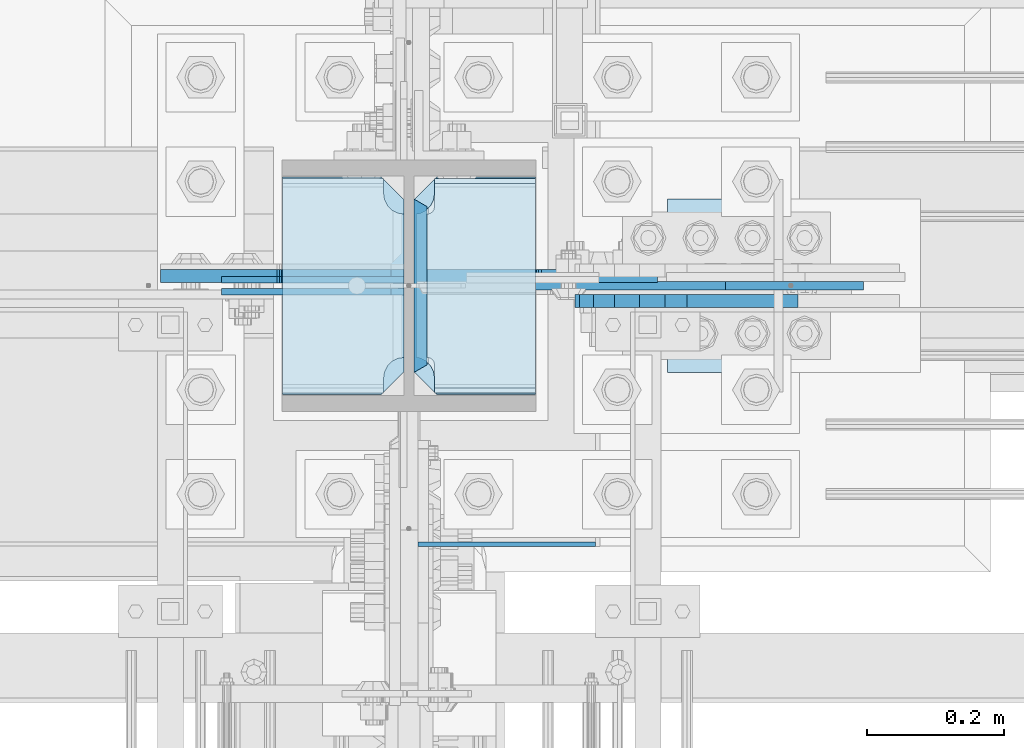
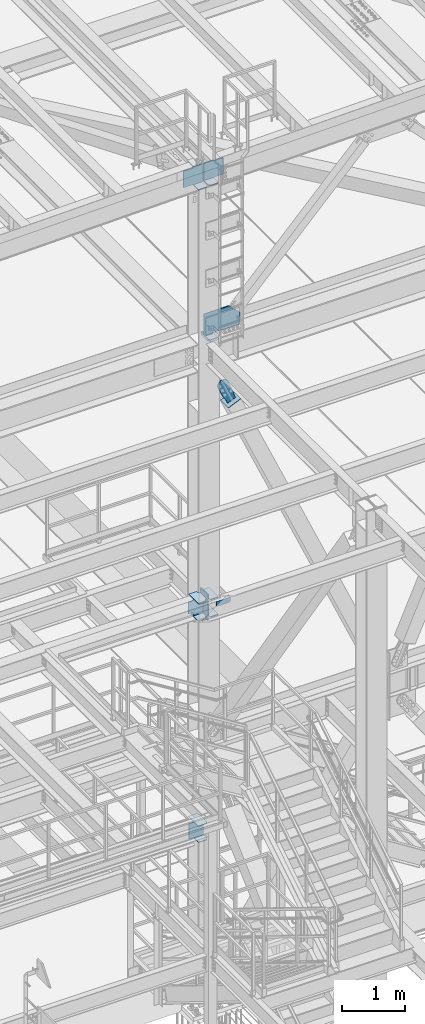
# One storey, part 3151 of 3843: 18 plates, 4 elements without a shape of their own.
"""IFC2X3 building model written with IfcOpenShell, lengths in millimetres."""

import ifcopenshell
import ifcopenshell.guid

model = None  # the IFC model being written
_history = None  # IfcOwnerHistory: only IFC2X3 demands one
_inside = {}  # id of a spatial element -> (the spatial element, [elements in it])
_under = {}  # id of a project, library or spatial element -> (it, [spatial elements below it])
_declared = {}  # id of a project -> (the project, [libraries it declares])
_typed = {}  # id of a type object -> (the type object, [elements of that type])
_made_of = {}  # id of a material, layer set ... -> (it, [elements and type objects made of it])


def new_model(schema):
    """Start an empty IFC model of exactly this schema.

    Asked for "IFC4X3", IfcOpenShell would pick the latest addendum, in which some entities
    have other attributes; the version numbers below select the first issue.
    IFC2X3 requires an IfcOwnerHistory on every rooted entity: one is made here for all.
    """
    global model, _history
    if schema == "IFC4X3":
        model = ifcopenshell.file(schema_version=(4, 3, 0, 0))
    else:
        model = ifcopenshell.file(schema=schema)
    _inside.clear()
    _under.clear()
    _declared.clear()
    _typed.clear()
    _made_of.clear()
    _history = None
    if model.schema == "IFC2X3":
        org = make("IfcOrganization", Name="unknown")
        user = make(
            "IfcPersonAndOrganization",
            ThePerson=make("IfcPerson", FamilyName="unknown"),
            TheOrganization=org,
        )
        app = make(
            "IfcApplication",
            ApplicationDeveloper=org,
            Version="unknown",
            ApplicationFullName="unknown",
            ApplicationIdentifier="unknown",
        )
        _history = make(
            "IfcOwnerHistory",
            OwningUser=user,
            OwningApplication=app,
            ChangeAction="ADDED",
            CreationDate=0,
        )
    return model


def make(cls, **values):
    """One entity of the class cls with the attributes given. An attribute that is None is left unset."""
    return model.create_entity(
        cls, **{name: value for name, value in values.items() if value is not None}
    )


def rooted(cls, **values):
    """An entity with a GlobalId (a new one), such as an element, a storey or a relation."""
    return make(cls, GlobalId=ifcopenshell.guid.new(), OwnerHistory=_history, **values)


def si_unit(unit_type, name, prefix=None):
    """IfcSIUnit, for example si_unit("LENGTHUNIT", "METRE", prefix="MILLI")."""
    return make("IfcSIUnit", UnitType=unit_type, Prefix=prefix, Name=name)


def assignment(units):
    """IfcUnitAssignment: the units of a project."""
    return None if units is None else make("IfcUnitAssignment", Units=units)


def point(xyz):
    """IfcCartesianPoint."""
    return None if xyz is None else make("IfcCartesianPoint", Coordinates=xyz)


def direction(xyz):
    """IfcDirection."""
    return None if xyz is None else make("IfcDirection", DirectionRatios=xyz)


def frame(location, z_axis=None, x_axis=None):
    """IfcAxis2Placement3D, a coordinate frame: its origin and axes. An axis left out is left unset."""
    return make(
        "IfcAxis2Placement3D",
        Location=point(location),
        Axis=direction(z_axis),
        RefDirection=direction(x_axis),
    )


def origin_with_axes():
    """The frame at (0, 0, 0) with the z axis (0, 0, 1) and the x axis (1, 0, 0) written out."""
    return frame((0.0, 0.0, 0.0), z_axis=(0.0, 0.0, 1.0), x_axis=(1.0, 0.0, 0.0))


def place(relative_to, where):
    """IfcLocalPlacement: puts the frame where relative to a parent placement (None: the world)."""
    return make(
        "IfcLocalPlacement", PlacementRelTo=relative_to, RelativePlacement=where
    )


def context(
    kind, dimensions, precision=None, world=None, true_north=None, identifier=None
):
    """IfcGeometricRepresentationContext, for example the 3D "Model" context."""
    return make(
        "IfcGeometricRepresentationContext",
        ContextIdentifier=identifier,
        ContextType=kind,
        CoordinateSpaceDimension=dimensions,
        Precision=precision,
        WorldCoordinateSystem=world,
        TrueNorth=true_north,
    )


def subcontext(parent, identifier, kind, view, scale=None):
    """IfcGeometricRepresentationSubContext, for example "Body" below "Model"."""
    return make(
        "IfcGeometricRepresentationSubContext",
        ContextIdentifier=identifier,
        ContextType=kind,
        ParentContext=parent,
        TargetScale=scale,
        TargetView=view,
    )


def project(units=None, contexts=None):
    """IfcProject with its units and contexts."""
    return rooted(
        "IfcProject",
        Name="project",
        RepresentationContexts=contexts,
        UnitsInContext=assignment(units),
    )


def spatial(cls, under=None, at=None, **own):
    """A site, building, storey or space (cls), placed at a placement, below another one or the project."""
    s = rooted(cls, ObjectPlacement=at, **own)
    if under is not None:
        _under.setdefault(under.id(), (under, []))[1].append(s)
    return s


def faces_of(points, faces, orient=None, outer=None):
    """IfcFace entities. A face is a list of loops; a loop is a list of indices into points, from 0.

    orient and outer hold one flag for each loop. By default every Orientation is true, the
    first loop of a face is its IfcFaceOuterBound and the others are IfcFaceBound.
    """
    made = []
    for i, loops in enumerate(faces):
        bounds = []
        for j, loop in enumerate(loops):
            is_outer = j == 0 if outer is None else outer[i][j]
            bounds.append(
                make(
                    "IfcFaceOuterBound" if is_outer else "IfcFaceBound",
                    Bound=make("IfcPolyLoop", Polygon=[points[k] for k in loop]),
                    Orientation=True if orient is None else orient[i][j],
                )
            )
        made.append(make("IfcFace", Bounds=bounds))
    return made


def faceted_brep(points, faces, orient=None, outer=None, voids=None):
    """IfcFacetedBrep: a solid bounded by flat faces; with voids (closed shells), ...WithVoids."""
    shared = [point(p) for p in points]
    hull = make("IfcClosedShell", CfsFaces=faces_of(shared, faces, orient, outer))
    if voids is None:
        return make("IfcFacetedBrep", Outer=hull)
    return make(
        "IfcFacetedBrepWithVoids",
        Outer=hull,
        Voids=[
            make(cls, CfsFaces=faces_of(shared, fs, o, b)) for cls, fs, o, b in voids
        ],
    )


def shape(context_of_items, identifier, shape_type, items):
    """IfcShapeRepresentation: the items that make up one representation, for example the "Body"."""
    return make(
        "IfcShapeRepresentation",
        ContextOfItems=context_of_items,
        RepresentationIdentifier=identifier,
        RepresentationType=shape_type,
        Items=items,
    )


def material(Name=None, Category=None):
    """IfcMaterial."""
    return make("IfcMaterial", Name=Name, Category=Category)


def made_of(thing, what):
    """Note that an element or type object is made of a material, layer set ...; save() writes the relation."""
    if what is not None:
        _made_of.setdefault(what.id(), (what, []))[1].append(thing)
    return thing


def type_object(cls, material=None, **own):
    """A type object (cls), such as IfcWallType, which elements share."""
    return made_of(rooted(cls, **own), material)


def element(
    cls,
    number,
    at=None,
    inside=None,
    cuts=None,
    type_object=None,
    material=None,
    context=None,
    identifier="Body",
    shape_type=None,
    held_by="IfcProductDefinitionShape",
    body=None,
    shapes=None,
    **own,
):
    """One element of the class cls, such as IfcWall. Its Tag is "e" and its number.

    at: its placement. inside: the storey or other place that contains it. cuts: it is an
    opening in that element (IfcRelVoidsElement). A single representation is given by context,
    identifier, shape_type and body (its items); several are given by shapes. held_by: the class
    of the entity that holds the representations. save() writes the other relations.
    """
    e = rooted(cls, Tag="e%d" % number, ObjectPlacement=at, **own)
    if body is not None:
        shapes = [shape(context, identifier, shape_type, body)]
    if shapes is not None:
        e.Representation = make(held_by, Representations=shapes)
    if inside is not None:
        _inside.setdefault(inside.id(), (inside, []))[1].append(e)
    if cuts is not None:
        rooted(
            "IfcRelVoidsElement", RelatingBuildingElement=cuts, RelatedOpeningElement=e
        )
    if type_object is not None:
        _typed.setdefault(type_object.id(), (type_object, []))[1].append(e)
    return made_of(e, material)


def aggregate(whole, parts):
    """IfcRelAggregates: a whole, such as a stair, and the parts it consists of."""
    return rooted("IfcRelAggregates", RelatingObject=whole, RelatedObjects=parts)


def save(model, path):
    """Write the relations noted so far, then the file.

    IfcRelAggregates (storeys below a building ...), IfcRelContainedInSpatialStructure (elements
    in a storey), IfcRelDefinesByType, IfcRelAssociatesMaterial and IfcRelDeclares: one each for
    every whole, place, type object, material and project.
    """
    for whole, parts in _under.values():
        aggregate(whole, parts)
    for where, things in _inside.values():
        rooted(
            "IfcRelContainedInSpatialStructure",
            RelatedElements=things,
            RelatingStructure=where,
        )
    for kind, things in _typed.values():
        rooted("IfcRelDefinesByType", RelatedObjects=things, RelatingType=kind)
    for what, things in _made_of.values():
        rooted("IfcRelAssociatesMaterial", RelatedObjects=things, RelatingMaterial=what)
    for by, libraries in _declared.values():
        rooted("IfcRelDeclares", RelatingContext=by, RelatedDefinitions=libraries)
    model.write(path)


model = new_model("IFC2X3")

# Units and contexts
model_context = context("Model", 3, precision=1e-05, world=origin_with_axes())
body_context = subcontext(model_context, "Body", "Model", "MODEL_VIEW")
ifc_project = project(units=[si_unit("LENGTHUNIT", "METRE", prefix="MILLI"), si_unit("AREAUNIT", "SQUARE_METRE"), si_unit("VOLUMEUNIT", "CUBIC_METRE"), si_unit("MASSUNIT", "GRAM", prefix="KILO"), si_unit("TIMEUNIT", "SECOND"), si_unit("PLANEANGLEUNIT", "RADIAN"), si_unit("SOLIDANGLEUNIT", "STERADIAN"), si_unit("THERMODYNAMICTEMPERATUREUNIT", "DEGREE_CELSIUS"), si_unit("LUMINOUSINTENSITYUNIT", "LUMEN")], contexts=[model_context])

# Site, building, storey
site_placement = place(None, origin_with_axes())
site = spatial("IfcSite", under=ifc_project, at=site_placement, CompositionType="ELEMENT")
building_placement = place(site_placement, origin_with_axes())
building = spatial("IfcBuilding", under=site, at=building_placement, Name="Undefined", CompositionType="ELEMENT")
storey_placement = place(building_placement, origin_with_axes())
storey = spatial("IfcBuildingStorey", under=building, at=storey_placement, Name="Undefined", CompositionType="ELEMENT", Elevation=0.0)

# Assembly, plates
assembly_1_placement = place(storey_placement, origin_with_axes())
assembly_1 = element("IfcElementAssembly", 1, at=assembly_1_placement, inside=storey, Name="COLUMN", AssemblyPlace="NOTDEFINED", PredefinedType="RIGID_FRAME")
ifc_material_1 = material(Name="STEEL/A572-50")
plate_type_1 = type_object("IfcPlateType", PredefinedType="NOTDEFINED")
plate_1_placement = place(assembly_1_placement, frame((55745.85625, 25776.2375, 37122.1), z_axis=(0.0, -1.0, 0.0), x_axis=(1.0, 0.0, 0.0)))
plate_1 = element("IfcPlate", 2, at=plate_1_placement, type_object=plate_type_1, material=ifc_material_1, Name="PLATE", context=body_context, shape_type="Brep", body=[
    faceted_brep([(147.637499618526, 6.34999999999854, 10.5078482601057), (147.637499618526, -6.34999999999854, 3.17549995151785), (0.0, -6.34999999999854, 3.17549995151785), (0.0, 6.34999999999854, 10.5078482601057), (0.0, 6.34999999999854, 310.168151738297), (0.0, -6.34999999999854, 317.500500046885), (147.637499618526, -6.34999999999854, 317.500500046885), (147.637499618526, 6.34999999999854, 310.168151738297), (147.637499618526, -6.34999999999854, 295.275000381469), (147.637499618526, 6.34999999999854, 295.275000381469), (149.113757464445, -6.34999999999854, 285.954275170756), (149.113757464445, 6.34999999999854, 285.954275170756), (153.398024598544, -6.34999999999854, 277.545927484975), (153.398024598544, 6.34999999999854, 277.545927484975), (160.070927103501, -6.34999999999854, 270.873024980021), (160.070927103501, 6.34999999999854, 270.873024980021), (168.479274789279, -6.34999999999854, 266.588757845919), (168.479274789279, 6.34999999999854, 266.588757845919), (177.799999999996, -6.34999999999854, 265.112499999999), (177.799999999996, 6.34999999999854, 265.112499999999), (177.799999999996, -6.34999999999854, 55.5625), (177.799999999996, 6.34999999999854, 55.5625), (168.479274789279, -6.34999999999854, 54.0862421540805), (168.479274789279, 6.34999999999854, 54.0862421540805), (160.070927103501, -6.34999999999854, 49.8019750199819), (160.070927103501, 6.34999999999854, 49.8019750199819), (153.398024598544, -6.34999999999854, 43.1290725150247), (153.398024598544, 6.34999999999854, 43.1290725150247), (149.113757464445, -6.34999999999854, 34.720724829247), (149.113757464445, 6.34999999999854, 34.720724829247), (147.637499618526, -6.34999999999854, 25.3999996185303), (147.637499618526, 6.34999999999854, 25.3999996185303)], [[[0, 1, 2, 3]], [[4, 5, 6, 7]], [[3, 2, 5, 4]], [[8, 9, 7, 6]], [[8, 10, 11, 9]], [[10, 12, 13, 11]], [[12, 14, 15, 13]], [[14, 16, 17, 15]], [[16, 18, 19, 17]], [[18, 20, 21, 19]], [[20, 22, 23, 21]], [[22, 24, 25, 23]], [[24, 26, 27, 25]], [[26, 28, 29, 27]], [[28, 30, 31, 29]], [[31, 30, 1, 0]], [[4, 7, 9, 11, 13, 15, 17, 19, 21, 23, 25, 27, 29, 31, 0, 3]], [[1, 30, 28, 26, 24, 22, 20, 18, 16, 14, 12, 10, 8, 6, 5, 2]]]),
])
plate_2_placement = place(assembly_1_placement, frame((55745.85625, 25776.2375, 37458.65), z_axis=(0.0, -1.0, 0.0), x_axis=(1.0, 0.0, 0.0)))
plate_2 = element("IfcPlate", 3, at=plate_2_placement, type_object=plate_type_1, material=ifc_material_1, Name="PLATE", context=body_context, shape_type="Brep", body=[
    faceted_brep([(147.637499618526, 6.34999999999854, 10.5078482601057), (147.637499618526, -6.34999999999854, 3.17549995151785), (0.0, -6.34999999999854, 3.17549995151785), (0.0, 6.34999999999854, 10.5078482601057), (0.0, 6.34999999999854, 310.168151738297), (0.0, -6.34999999999854, 317.500500046885), (147.637499618526, -6.34999999999854, 317.500500046885), (147.637499618526, 6.34999999999854, 310.168151738297), (147.637499618526, -6.34999999999854, 295.275000381469), (147.637499618526, 6.34999999999854, 295.275000381469), (149.113757464445, -6.34999999999854, 285.954275170756), (149.113757464445, 6.34999999999854, 285.954275170756), (153.398024598544, -6.34999999999854, 277.545927484975), (153.398024598544, 6.34999999999854, 277.545927484975), (160.070927103501, -6.34999999999854, 270.873024980021), (160.070927103501, 6.34999999999854, 270.873024980021), (168.479274789279, -6.34999999999854, 266.588757845919), (168.479274789279, 6.34999999999854, 266.588757845919), (177.799999999996, -6.34999999999854, 265.112499999999), (177.799999999996, 6.34999999999854, 265.112499999999), (177.799999999996, -6.34999999999854, 55.5625), (177.799999999996, 6.34999999999854, 55.5625), (168.479274789279, -6.34999999999854, 54.0862421540805), (168.479274789279, 6.34999999999854, 54.0862421540805), (160.070927103501, -6.34999999999854, 49.8019750199819), (160.070927103501, 6.34999999999854, 49.8019750199819), (153.398024598544, -6.34999999999854, 43.1290725150247), (153.398024598544, 6.34999999999854, 43.1290725150247), (149.113757464445, -6.34999999999854, 34.720724829247), (149.113757464445, 6.34999999999854, 34.720724829247), (147.637499618526, -6.34999999999854, 25.3999996185303), (147.637499618526, 6.34999999999854, 25.3999996185303)], [[[0, 1, 2, 3]], [[4, 5, 6, 7]], [[3, 2, 5, 4]], [[8, 9, 7, 6]], [[8, 10, 11, 9]], [[10, 12, 13, 11]], [[12, 14, 15, 13]], [[14, 16, 17, 15]], [[16, 18, 19, 17]], [[18, 20, 21, 19]], [[20, 22, 23, 21]], [[22, 24, 25, 23]], [[24, 26, 27, 25]], [[26, 28, 29, 27]], [[28, 30, 31, 29]], [[31, 30, 1, 0]], [[4, 7, 9, 11, 13, 15, 17, 19, 21, 23, 25, 27, 29, 31, 0, 3]], [[1, 30, 28, 26, 24, 22, 20, 18, 16, 14, 12, 10, 8, 6, 5, 2]]]),
])

# Assembly, plate
assembly_2_placement = place(storey_placement, origin_with_axes())
assembly_2 = element("IfcElementAssembly", 4, at=assembly_2_placement, inside=storey, Name="BEAM", AssemblyPlace="NOTDEFINED", PredefinedType="RIGID_FRAME")
plate_type_2 = type_object("IfcPlateType", PredefinedType="NOTDEFINED")
plate_3_placement = place(assembly_2_placement, frame((55943.5, 25237.8457862042, 37471.35), z_axis=(0.0, 0.0, 1.0), x_axis=(1.0, 0.0, 0.0)))
plate_3 = element("IfcPlate", 5, at=plate_3_placement, type_object=plate_type_2, material=ifc_material_1, Name="PLATE", context=body_context, shape_type="Brep", body=[
    faceted_brep([(0.0, -3.17499999999927, 0.0), (0.0, -3.17499999999927, 95.25), (-2.44140610448085e-05, 3.17500000000291, 95.2499999999927), (0.0, 3.17499999999927, 0.0), (260.350006103516, -3.17499999999927, 95.25), (260.350006103516, 3.17499999999927, 95.25), (260.350006103516, -3.17499999999927, 19.0499992370605), (260.350006103516, 3.17499999999927, 19.0499992370605), (241.300006866455, -3.17499999999927, 0.0), (241.300006866455, 3.17499999999927, 0.0)], [[[0, 1, 2, 3]], [[1, 4, 5, 2]], [[4, 6, 7, 5]], [[6, 8, 9, 7]], [[8, 0, 3, 9]], [[5, 7, 9, 3, 2]], [[8, 6, 4, 1, 0]]]),
])
aggregate(assembly_2, [plate_3])

# Plate
plate_type_3 = type_object("IfcPlateType", PredefinedType="NOTDEFINED")
plate_4_placement = place(assembly_1_placement, frame((55745.85625, 25774.65, 32850.1375), z_axis=(0.0, -1.0, 0.0), x_axis=(1.0, 0.0, 0.0)))
plate_4 = element("IfcPlate", 6, at=plate_4_placement, type_object=plate_type_3, material=ifc_material_1, Name="PLATE", context=body_context, shape_type="Brep", body=[
    faceted_brep([(0.0, -4.76249999999709, 0.0), (0.0, -4.76249999785796, 317.500000005042), (0.0, 4.76250000210712, 317.50000000505), (0.0, 4.76249999999709, 0.0), (144.462501525879, -4.76249999999709, 317.5), (144.462501525879, 4.76249999999709, 317.5), (177.800003051758, -4.76249999999709, 284.162498474121), (177.800003051758, 4.76249999999709, 284.162498474121), (177.800003051758, -4.76249999999709, 33.3375015258789), (177.800003051758, 4.76249999999709, 33.3375015258789), (144.462501525879, -4.76249999999709, 0.0), (144.462501525879, 4.76249999999709, 0.0)], [[[0, 1, 2, 3]], [[1, 4, 5, 2]], [[4, 6, 7, 5]], [[6, 8, 9, 7]], [[8, 10, 11, 9]], [[10, 0, 3, 11]], [[5, 7, 9, 11, 3, 2]], [[10, 8, 6, 4, 1, 0]]]),
])

plate_5_placement = place(assembly_1_placement, frame((55745.85625, 25774.65, 33164.4625), z_axis=(0.0, -1.0, 0.0), x_axis=(1.0, 0.0, 0.0)))
plate_5 = element("IfcPlate", 7, at=plate_5_placement, type_object=plate_type_3, material=ifc_material_1, Name="PLATE", context=body_context, shape_type="Brep", body=[
    faceted_brep([(0.0, -4.76249999999709, 0.0), (0.0, -4.76249999785796, 317.500000005042), (0.0, 4.76250000210712, 317.50000000505), (0.0, 4.76249999999709, 0.0), (144.462501525879, -4.76249999999709, 317.5), (144.462501525879, 4.76249999999709, 317.5), (177.800003051758, -4.76249999999709, 284.162498474121), (177.800003051758, 4.76249999999709, 284.162498474121), (177.800003051758, -4.76249999999709, 33.3375015258789), (177.800003051758, 4.76249999999709, 33.3375015258789), (144.462501525879, -4.76249999999709, 0.0), (144.462501525879, 4.76249999999709, 0.0)], [[[0, 1, 2, 3]], [[1, 4, 5, 2]], [[4, 6, 7, 5]], [[6, 8, 9, 7]], [[8, 10, 11, 9]], [[10, 0, 3, 11]], [[5, 7, 9, 11, 3, 2]], [[10, 8, 6, 4, 1, 0]]]),
])

plate_type_4 = type_object("IfcPlateType", PredefinedType="NOTDEFINED")
plate_6_placement = place(assembly_1_placement, frame((56115.74375, 25455.5625, 42452.925), z_axis=(0.0, 1.0, 0.0), x_axis=(-1.0, 0.0, 0.0)))
plate_6 = element("IfcPlate", 8, at=plate_6_placement, type_object=plate_type_4, material=ifc_material_1, Name="PLATE", context=body_context, shape_type="Brep", body=[
    faceted_brep([(160.070927103507, 9.33349681380059, 49.8019750199746), (156.294129000915, 15.875, 46.0251769173919), (156.294129000915, 15.875, 274.649823082611), (160.070927103507, 9.33349681380059, 270.873024980028), (168.479274789286, -5.22995923629787, 266.588757845922), (174.625000047685, -15.875, 265.615370590487), (174.625000047685, -15.875, 55.0596294095158), (168.479274789286, -5.22995923629787, 54.0862421540805), (147.637499618526, 15.875, 21.5063709990791), (147.637499618526, -15.875, 3.17549995230729), (0.0, -15.875, 3.17549995230729), (0.0, 15.875, 21.5063709990791), (0.0, 15.875, 299.169629000906), (0.0, -15.875, 317.500500047678), (147.637499618526, -15.875, 317.500500047678), (147.637499618526, 15.875, 299.169629000906), (147.637499618531, -15.875, 295.275000381473), (147.637499618531, 15.875, 295.275000381473), (149.113757464449, -15.875, 285.954275170763), (149.113757464449, 15.875, 285.954275170763), (153.398024598551, -15.875, 277.545927484985), (153.398024598551, 15.875, 277.545927484985), (160.070927103507, -15.875, 270.873024980028), (168.479274789286, -15.875, 266.588757845922), (168.479274789286, -15.875, 54.0862421540805), (160.070927103507, -15.875, 49.8019750199746), (153.398024598551, -15.875, 43.1290725150175), (153.398024598551, 15.875, 43.1290725150175), (149.113757464449, -15.875, 34.7207248292398), (149.113757464449, 15.875, 34.7207248292398), (147.637499618531, -15.875, 25.3999996185303), (147.637499618531, 15.875, 25.3999996185303)], [[[0, 1, 2, 3, 4, 5, 6, 7]], [[8, 9, 10, 11]], [[12, 13, 14, 15]], [[13, 12, 11, 10]], [[16, 17, 15, 14]], [[16, 18, 19, 17]], [[18, 20, 21, 19]], [[21, 20, 22, 3, 2]], [[22, 23, 4, 3]], [[23, 5, 4]], [[24, 7, 6]], [[24, 25, 0, 7]], [[25, 26, 27, 1, 0]], [[26, 28, 29, 27]], [[28, 30, 31, 29]], [[31, 30, 9, 8]], [[27, 29, 31, 8, 11, 12, 15, 17, 19, 21, 2, 1]], [[9, 30, 28, 26, 25, 24, 6, 5, 23, 22, 20, 18, 16, 14, 13, 10]]]),
])

plate_type_5 = type_object("IfcPlateType", PredefinedType="NOTDEFINED")
plate_7_placement = place(assembly_1_placement, frame((56115.74375, 25457.15, 45462.0789825252), z_axis=(0.0, 1.0, 0.0), x_axis=(-1.0, 0.0, 0.0)))
plate_7 = element("IfcPlate", 9, at=plate_7_placement, type_object=plate_type_5, material=ifc_material_1, Name="PLATE", context=body_context, shape_type="Brep", body=[
    faceted_brep([(0.0, -9.52500000000146, 0.0), (0.0, -9.52500000000146, 317.5), (0.0, 9.52500000000146, 317.5), (0.0, 9.52500000000146, 0.0), (144.462501525879, -9.52500000000146, 317.5), (144.462501525879, 9.52500000000146, 317.5), (177.800003051758, -9.52500000000146, 284.162498474121), (177.800003051758, 9.52500000000146, 284.162498474121), (177.800003051758, -9.52500000000146, 33.3375015258789), (177.800003051758, 9.52500000000146, 33.3375015258789), (144.462501525879, -9.52500000000146, 0.0), (144.462501525879, 9.52500000000146, 0.0)], [[[0, 1, 2, 3]], [[1, 4, 5, 2]], [[4, 6, 7, 5]], [[6, 8, 9, 7]], [[8, 10, 11, 9]], [[10, 0, 3, 11]], [[5, 7, 9, 11, 3, 2]], [[10, 8, 6, 4, 1, 0]]]),
])

plate_8_placement = place(assembly_1_placement, frame((55745.8562499977, 25774.6499999999, 45450.5073620301), z_axis=(0.0, -1.0, 0.0), x_axis=(1.0, 0.0, 0.0)))
plate_8 = element("IfcPlate", 10, at=plate_8_placement, type_object=plate_type_5, material=ifc_material_1, Name="PLATE", context=body_context, shape_type="Brep", body=[
    faceted_brep([(0.0, -9.52500000000146, 0.0), (0.0, -9.52500000000146, 317.5), (0.0, 9.52500000000146, 317.5), (0.0, 9.52500000000146, 0.0), (144.462501525879, -9.52500000000146, 317.5), (144.462501525879, 9.52500000000146, 317.5), (177.800003051758, -9.52500000000146, 284.162498474121), (177.800003051758, 9.52500000000146, 284.162498474121), (177.800003051758, -9.52500000000146, 33.3375015258789), (177.800003051758, 9.52500000000146, 33.3375015258789), (144.462501525879, -9.52500000000146, 0.0), (144.462501525879, 9.52500000000146, 0.0)], [[[0, 1, 2, 3]], [[1, 4, 5, 2]], [[4, 6, 7, 5]], [[6, 8, 9, 7]], [[8, 10, 11, 9]], [[10, 0, 3, 11]], [[5, 7, 9, 11, 3, 2]], [[10, 8, 6, 4, 1, 0]]]),
])

plate_type_6 = type_object("IfcPlateType", PredefinedType="NOTDEFINED")
plate_9_placement = place(assembly_1_placement, frame((55947.46875, 25489.0875, 37541.2), z_axis=(0.0, 1.0, 0.0), x_axis=(0.0, 0.0, -1.0)))
plate_9 = element("IfcPlate", 11, at=plate_9_placement, type_object=plate_type_6, material=ifc_material_1, Name="PLATE", context=body_context, shape_type="Brep", body=[
    faceted_brep([(0.0, -9.52500000000146, 242.626477373742), (501.650000000001, -9.52500000000146, 242.626477373742), (501.650000000001, 9.52500000000146, 253.625), (0.0, 9.52500000000146, 253.625), (501.650000000001, -9.52500000000146, 10.9985226253266), (501.650000000001, 9.52500000000146, 0.0), (0.0, 9.52500000000146, 0.0), (0.0, -9.52500000000146, 10.9985226253266)], [[[0, 1, 2, 3]], [[2, 1, 4, 5]], [[3, 2, 5, 6]], [[0, 3, 6, 7]], [[1, 0, 7, 4]], [[6, 5, 4, 7]]]),
])

# Assembly, plate
assembly_3_placement = place(storey_placement, origin_with_axes())
assembly_3 = element("IfcElementAssembly", 12, at=assembly_3_placement, inside=storey, AssemblyPlace="NOTDEFINED", PredefinedType="RIGID_FRAME")
ifc_material_2 = material(Name="STEEL/A36")
plate_type_7 = type_object("IfcPlateType", PredefinedType="NOTDEFINED")
plate_10_placement = place(assembly_3_placement, frame((56471.840024458, 25593.675, 41169.8056493382), z_axis=(-0.915217968956094, 0.0, -0.402959140980674), x_axis=(0.402959140980677, 0.0, -0.915217968956092)))
plate_10 = element("IfcPlate", 13, at=plate_10_placement, type_object=plate_type_7, material=ifc_material_2, context=body_context, shape_type="Brep", body=[
    faceted_brep([(0.0, -9.52500000000146, 0.0), (-101.599999999169, -9.52499999999418, -17.6403935107228), (-101.599999999169, 9.52499999999418, -17.6403935107228), (0.0, 9.52500000000146, 0.0), (-320.279297659972, -9.52499999999418, -17.640393512258), (-320.279297659972, 9.52499999999418, -17.640393512258), (-357.3374051259, -9.52499999999418, -10.2690776257878), (-357.3374051259, 9.52499999999418, -10.2690776257878), (-388.753751662653, -9.52499999999418, 10.7226540115298), (-388.753751662653, 9.52499999999418, 10.7226540115298), (-409.745483299826, -9.52499999999418, 42.1390005483918), (-409.745483299826, 9.52499999999418, 42.1390005483918), (-417.116799186137, -9.52499999999418, 79.1971049608474), (-417.116799186137, 9.52499999999418, 79.1971049608474), (-409.745483299252, -9.52499999999418, 116.255212426157), (-409.745483299252, 9.52499999999418, 116.255212426157), (-388.75375166202, -9.52499999999418, 147.671558962465), (-388.75375166202, 9.52499999999418, 147.671558962465), (-357.33740512564, -9.52499999999418, 168.663290599579), (-357.33740512564, 9.52499999999418, 168.663290599579), (-320.279299186061, -9.52499999999418, 176.034606486319), (-320.279299186061, 9.52499999999418, 176.034606486319), (-101.599999997048, -9.52499999999418, 176.034606487883), (-101.599999997048, 9.52499999999418, 176.034606487883), (1.71894498635083e-09, -9.52499999999418, 158.39421297863), (1.71894498635083e-09, 9.52499999999418, 158.39421297863), (69.8500000010408, -9.52499999999418, 158.394212979103), (69.8500000010408, 9.52499999999418, 158.394212979103), (69.8499999979995, -9.52499999999418, -4.00177668780088e-10), (69.8499999979995, 9.52499999999418, -4.00177668780088e-10)], [[[0, 1, 2, 3]], [[1, 4, 5, 2]], [[4, 6, 7, 5]], [[6, 8, 9, 7]], [[8, 10, 11, 9]], [[10, 12, 13, 11]], [[12, 14, 15, 13]], [[14, 16, 17, 15]], [[16, 18, 19, 17]], [[18, 20, 21, 19]], [[20, 22, 23, 21]], [[22, 24, 25, 23]], [[24, 26, 27, 25]], [[26, 28, 29, 27]], [[28, 0, 3, 29]], [[5, 7, 9, 11, 13, 15, 17, 19, 21, 23, 25, 27, 29, 3, 2]], [[28, 26, 24, 22, 20, 18, 16, 14, 12, 10, 8, 6, 4, 1, 0]]]),
])
aggregate(assembly_3, [plate_10])

assembly_4_placement = place(storey_placement, origin_with_axes())
assembly_4 = element("IfcElementAssembly", 14, at=assembly_4_placement, inside=storey, Name="Plate", AssemblyPlace="NOTDEFINED", PredefinedType="RIGID_FRAME")
plate_type_8 = type_object("IfcPlateType", PredefinedType="NOTDEFINED")
plate_11_placement = place(assembly_4_placement, frame((56309.9920282698, 25742.9, 41025.6944824161), z_axis=(0.9152179689561, 0.0, 0.402959140980659), x_axis=(0.0, -1.0, 0.0)))
plate_11 = element("IfcPlate", 15, at=plate_11_placement, type_object=plate_type_8, material=ifc_material_2, Name="Plate", context=body_context, shape_type="Brep", body=[
    faceted_brep([(0.0, -3.17499999999927, 0.0), (0.0, -3.17499999965185, 254.000000005151), (0.0, 3.17500000035216, 254.000000005166), (0.0, 3.17499999999927, 0.0), (254.0, -3.17499999965185, 254.000000005151), (254.0, 3.17500000035216, 254.000000005166), (254.0, -3.17500000000291, 0.0), (254.0, 3.17499999999927, 1.45519152283669e-11)], [[[0, 1, 2, 3]], [[1, 4, 5, 2]], [[4, 6, 7, 5]], [[6, 0, 3, 7]], [[5, 7, 3, 2]], [[6, 4, 1, 0]]]),
])
aggregate(assembly_4, [plate_11])

# Plate
plate_type_9 = type_object("IfcPlateType", PredefinedType="NOTDEFINED")
plate_12_placement = place(assembly_1_placement, frame((55937.9437500005, 25615.8999998765, 42468.7999999995), z_axis=(1.0, 0.0, 0.0), x_axis=(0.0, 0.0, 1.0)))
plate_12 = element("IfcPlate", 16, at=plate_12_placement, type_object=plate_type_9, material=ifc_material_1, Name="PLATE", context=body_context, shape_type="Brep", body=[
    faceted_brep([(19.0499992370605, -6.34999999999854, 0.0), (0.0, -6.34999999999854, 19.0499992370605), (0.0, 6.34999999999854, 19.0499992370605), (19.0499992370605, 6.34999999999854, 0.0), (25.4000002011162, -6.35000000000582, 153.193750006707), (25.4000002011162, 6.35000000000582, 153.193750006707), (0.0, 6.35000000000582, 153.193750006707), (0.0, -6.35000000000582, 153.193750006707), (30.2600797191626, -6.35000000000582, 154.160479929295), (30.2600797191626, 6.35000000000582, 154.160479929295), (34.3802561873163, -6.35000000000582, 156.913493829772), (34.3802561873163, 6.35000000000582, 156.913493829772), (37.1332700877902, -6.35000000000582, 161.033670297926), (37.1332700877902, 6.35000000000582, 161.033670297926), (38.1000000103813, -6.35000000000582, 165.893749815972), (38.1000000103813, 6.35000000000582, 165.893749815972), (38.1000000103813, -6.35000000000582, 191.293750197441), (38.1000000103813, 6.35000000000582, 191.293750197441), (37.1332700877902, -6.35000000000582, 196.153829715488), (37.1332700877902, 6.35000000000582, 196.153829715488), (34.3802561873163, -6.35000000000582, 200.274006183641), (34.3802561873163, 6.35000000000582, 200.274006183641), (30.2600797191626, -6.35000000000582, 203.027020084119), (30.2600797191626, 6.35000000000582, 203.027020084119), (25.4000002011162, -6.35000000000582, 203.993750006706), (25.4000002011162, 6.35000000000582, 203.993750006706), (12.6999999999971, -6.35000000000582, 203.993750006706), (12.6999999999971, 6.35000000000582, 203.993750006706), (12.7000000005137, -6.34999999999854, 657.538050779636), (12.7000000005137, 6.34999999999854, 657.538050779636), (237.691562785571, -6.34999999999854, 657.538050779636), (237.691562785571, 6.34999999999854, 657.538050779636), (431.157586934583, -6.34999999999854, 455.956162952447), (431.157586934583, 6.34999999999854, 455.956162952447), (431.157586934591, -6.35000000000582, 0.0), (431.157586934591, 6.35000000000582, 0.0)], [[[0, 1, 2, 3]], [[4, 5, 6, 7]], [[8, 9, 5, 4]], [[10, 11, 9, 8]], [[12, 13, 11, 10]], [[14, 15, 13, 12]], [[16, 17, 15, 14]], [[18, 19, 17, 16]], [[20, 21, 19, 18]], [[22, 23, 21, 20]], [[24, 25, 23, 22]], [[26, 27, 25, 24]], [[28, 29, 27, 26]], [[30, 31, 29, 28]], [[30, 32, 33, 31]], [[32, 34, 35, 33]], [[35, 34, 0, 3]], [[6, 5, 9, 11, 13, 15, 17, 19, 21, 23, 25, 27, 29, 31, 33, 35, 3, 2]], [[2, 1, 7, 6]], [[34, 32, 30, 28, 26, 24, 22, 20, 18, 16, 14, 12, 10, 8, 4, 7, 1, 0]]]),
])

plate_type_10 = type_object("IfcPlateType", PredefinedType="NOTDEFINED")
plate_13_placement = place(assembly_1_placement, frame((56115.74375, 25455.5625, 37122.1), z_axis=(0.0, 1.0, 0.0), x_axis=(-1.0, 0.0, 0.0)))
plate_13 = element("IfcPlate", 17, at=plate_13_placement, type_object=plate_type_10, material=ifc_material_1, Name="PLATE", context=body_context, shape_type="Brep", body=[
    faceted_brep([(147.637499809265, 6.34999999999854, 10.5068482617207), (147.637499809265, -6.34999999999854, 3.17449995313291), (0.0, -6.34999999999854, 3.17449995313291), (0.0, 6.34999999999854, 10.5068482617207), (0.0, 6.34999999999854, 310.167151739912), (0.0, -6.34999999999854, 317.4995000485), (147.637499809265, -6.34999999999854, 317.4995000485), (147.637499809265, 6.34999999999854, 310.167151739912), (147.637499809265, -6.34999999999854, 276.225000190734), (147.637499809265, 6.34999999999854, 276.225000190734), (148.483388518755, -6.34999999999854, 271.972430475587), (148.483388518755, 6.34999999999854, 271.972430475587), (150.892275759194, -6.34999999999854, 268.367275949928), (150.892275759194, 6.34999999999854, 268.367275949928), (154.49743028485, -6.34999999999854, 265.958388709485), (154.49743028485, 6.34999999999854, 265.958388709485), (158.75, -6.34999999999854, 265.112499999999), (158.75, 6.34999999999854, 265.112499999999), (158.75, -6.34999999999854, 55.5625), (158.75, 6.34999999999854, 55.5625), (154.49743028485, -6.34999999999854, 54.7166112905143), (154.49743028485, 6.34999999999854, 54.7166112905143), (150.892275759194, -6.34999999999854, 52.3077240500716), (150.892275759194, 6.34999999999854, 52.3077240500716), (148.483388518755, -6.34999999999854, 48.702569524412), (148.483388518755, 6.34999999999854, 48.702569524412), (147.637499809265, -6.34999999999854, 44.4499998092651), (147.637499809265, 6.34999999999854, 44.4499998092651)], [[[0, 1, 2, 3]], [[4, 5, 6, 7]], [[5, 4, 3, 2]], [[8, 9, 7, 6]], [[8, 10, 11, 9]], [[10, 12, 13, 11]], [[12, 14, 15, 13]], [[14, 16, 17, 15]], [[16, 18, 19, 17]], [[18, 20, 21, 19]], [[20, 22, 23, 21]], [[22, 24, 25, 23]], [[24, 26, 27, 25]], [[27, 26, 1, 0]], [[4, 7, 9, 11, 13, 15, 17, 19, 21, 23, 25, 27, 0, 3]], [[1, 26, 24, 22, 20, 18, 16, 14, 12, 10, 8, 6, 5, 2]]]),
])

plate_14_placement = place(assembly_1_placement, frame((56115.74375, 25455.5625, 37458.65), z_axis=(0.0, 1.0, 0.0), x_axis=(-1.0, 0.0, 0.0)))
plate_14 = element("IfcPlate", 18, at=plate_14_placement, type_object=plate_type_10, material=ifc_material_1, Name="PLATE", context=body_context, shape_type="Brep", body=[
    faceted_brep([(147.637499809265, 6.34999999999854, 10.5068482617207), (147.637499809265, -6.34999999999854, 3.17449995313291), (0.0, -6.34999999999854, 3.17449995313291), (0.0, 6.34999999999854, 10.5068482617207), (0.0, 6.34999999999854, 310.167151739912), (0.0, -6.34999999999854, 317.4995000485), (147.637499809265, -6.34999999999854, 317.4995000485), (147.637499809265, 6.34999999999854, 310.167151739912), (147.637499809265, -6.34999999999854, 276.225000190734), (147.637499809265, 6.34999999999854, 276.225000190734), (148.483388518755, -6.34999999999854, 271.972430475587), (148.483388518755, 6.34999999999854, 271.972430475587), (150.892275759194, -6.34999999999854, 268.367275949928), (150.892275759194, 6.34999999999854, 268.367275949928), (154.49743028485, -6.34999999999854, 265.958388709485), (154.49743028485, 6.34999999999854, 265.958388709485), (158.75, -6.34999999999854, 265.112499999999), (158.75, 6.34999999999854, 265.112499999999), (158.75, -6.34999999999854, 55.5625), (158.75, 6.34999999999854, 55.5625), (154.49743028485, -6.34999999999854, 54.7166112905143), (154.49743028485, 6.34999999999854, 54.7166112905143), (150.892275759194, -6.34999999999854, 52.3077240500716), (150.892275759194, 6.34999999999854, 52.3077240500716), (148.483388518755, -6.34999999999854, 48.702569524412), (148.483388518755, 6.34999999999854, 48.702569524412), (147.637499809265, -6.34999999999854, 44.4499998092651), (147.637499809265, 6.34999999999854, 44.4499998092651)], [[[0, 1, 2, 3]], [[4, 5, 6, 7]], [[5, 4, 3, 2]], [[8, 9, 7, 6]], [[8, 10, 11, 9]], [[10, 12, 13, 11]], [[12, 14, 15, 13]], [[14, 16, 17, 15]], [[16, 18, 19, 17]], [[18, 20, 21, 19]], [[20, 22, 23, 21]], [[22, 24, 25, 23]], [[24, 26, 27, 25]], [[27, 26, 1, 0]], [[4, 7, 9, 11, 13, 15, 17, 19, 21, 23, 25, 27, 0, 3]], [[1, 26, 24, 22, 20, 18, 16, 14, 12, 10, 8, 6, 5, 2]]]),
])

plate_type_11 = type_object("IfcPlateType", PredefinedType="NOTDEFINED")
plate_15_placement = place(assembly_1_placement, frame((55923.65625, 25624.6317499161, 37452.3), z_axis=(-1.0, 0.0, 0.0), x_axis=(0.0, 0.0, -1.0)))
plate_15 = element("IfcPlate", 19, at=plate_15_placement, type_object=plate_type_11, material=ifc_material_1, Name="PLATE", context=body_context, shape_type="Brep", body=[
    faceted_brep([(0.0, -4.76249999999709, 0.0), (0.0, -4.76250000000073, 178.59375), (0.0, 4.76250000000073, 178.59375), (0.0, 4.76249999999709, 0.0), (12.7000001907363, -4.76250000000073, 178.59375), (12.7000001907363, 4.76250000000073, 178.59375), (17.5600797087827, -4.76250000000073, 179.560479922591), (17.5600797087827, 4.76250000000073, 179.560479922591), (21.6802561769364, -4.76250000000073, 182.313493823065), (21.6802561769364, 4.76250000000073, 182.313493823065), (24.4332700774103, -4.76250000000073, 186.433670291219), (24.4332700774103, 4.76250000000073, 186.433670291219), (25.4000000000015, -4.76250000000073, 191.293749809265), (25.4000000000015, 4.76250000000073, 191.293749809265), (25.4000000000015, -4.76250000000073, 267.493749999994), (25.4000000000015, 4.76250000000073, 267.493749999994), (254.0, -4.76250000000073, 267.493749999994), (254.0, 4.76250000000073, 267.493749999994), (254.0, -4.76250000000073, 191.293749809265), (254.0, 4.76250000000073, 191.293749809265), (254.966729922591, -4.76250000000073, 186.433670291219), (254.966729922591, 4.76250000000073, 186.433670291219), (257.719743823065, -4.76250000000073, 182.313493823065), (257.719743823065, 4.76250000000073, 182.313493823065), (261.839920291219, -4.76250000000073, 179.560479922591), (261.839920291219, 4.76250000000073, 179.560479922591), (266.699999809265, -4.76250000000073, 178.59375), (266.699999809265, 4.76250000000073, 178.59375), (323.849999999999, -4.76250000000073, 178.59375), (323.849999999999, 4.76250000000073, 178.59375), (323.849987792972, -4.76249999999709, -1.45519152283669e-11), (323.849987792972, 4.76249999999709, -1.45519152283669e-11)], [[[0, 1, 2, 3]], [[1, 4, 5, 2]], [[4, 6, 7, 5]], [[6, 8, 9, 7]], [[8, 10, 11, 9]], [[10, 12, 13, 11]], [[12, 14, 15, 13]], [[14, 16, 17, 15]], [[16, 18, 19, 17]], [[18, 20, 21, 19]], [[20, 22, 23, 21]], [[22, 24, 25, 23]], [[24, 26, 27, 25]], [[26, 28, 29, 27]], [[28, 30, 31, 29]], [[30, 0, 3, 31]], [[5, 7, 9, 11, 13, 15, 17, 19, 21, 23, 25, 27, 29, 31, 3, 2]], [[30, 28, 26, 24, 22, 20, 18, 16, 14, 12, 10, 8, 6, 4, 1, 0]]]),
])

plate_type_12 = type_object("IfcPlateType", PredefinedType="NOTDEFINED")
plate_16_placement = place(assembly_1_placement, frame((55937.94375, 25630.1875003815, 45490.6539824988), z_axis=(0.707106781186548, 0.0, 0.707106781186548), x_axis=(0.707106781186548, 0.0, -0.707106781186548)))
plate_16 = element("IfcPlate", 20, at=plate_16_placement, type_object=plate_type_12, material=ifc_material_1, Name="PLATE", context=body_context, shape_type="Brep", body=[
    faceted_brep([(0.0, -9.52500000000146, 0.0), (-209.979301496754, -9.52500000000146, 209.979301496671), (-209.979301496754, 9.52500000000146, 209.979301496671), (0.0, 9.52500000000146, 0.0), (-209.979301496471, -9.52500000000146, 236.920069860033), (-209.979301496471, 9.52500000000146, 236.920069860033), (-97.1648339737767, -9.52500000000146, 349.734537382756), (-97.1648339737767, 9.52500000000146, 349.734537382756), (-93.3396839560301, -9.52500000000146, 345.909387365013), (-93.3396839560301, 9.52500000000146, 345.909387365013), (-89.219507487891, -9.52500000000146, 343.156373464546), (-89.219507487891, 9.52500000000146, 343.156373464546), (-84.35942796983, -9.52500000000146, 342.189643541991), (-84.35942796983, 9.52500000000146, 342.189643541991), (-79.4993484517727, -9.52500000000146, 343.15637346459), (-79.4993484517727, 9.52500000000146, 343.15637346459), (-75.3791719835863, -9.52500000000146, 345.909387365115), (-75.3791719835863, 9.52500000000146, 345.909387365115), (41.3641577270682, -9.52500000000146, 462.652717075805), (41.3641577270682, 9.52500000000146, 462.652717075805), (265.870560752759, -9.52500000000146, 238.146314050202), (265.870560752759, 9.52500000000146, 238.146314050202), (26.9407683632344, -9.52499999999964, 2.03726813197136e-10), (26.9407683632344, 9.52499999999964, 2.03726813197136e-10)], [[[0, 1, 2, 3]], [[1, 4, 5, 2]], [[4, 6, 7, 5]], [[6, 8, 9, 7]], [[8, 10, 11, 9]], [[10, 12, 13, 11]], [[12, 14, 15, 13]], [[14, 16, 17, 15]], [[16, 18, 19, 17]], [[18, 20, 21, 19]], [[20, 22, 23, 21]], [[22, 0, 3, 23]], [[5, 7, 9, 11, 13, 15, 17, 19, 21, 23, 3, 2]], [[22, 20, 18, 16, 14, 12, 10, 8, 6, 4, 1, 0]]]),
])

plate_type_13 = type_object("IfcPlateType", PredefinedType="NOTDEFINED")
plate_17_placement = place(assembly_1_placement, frame((55923.65625, 25630.1875003815, 45479.082361933), z_axis=(-0.707106781186548, 0.0, 0.707106781186548), x_axis=(-0.707106781186548, 0.0, -0.707106781186548)))
plate_17 = element("IfcPlate", 21, at=plate_17_placement, type_object=plate_type_13, material=ifc_material_1, Name="PLATE", context=body_context, shape_type="Brep", body=[
    faceted_brep([(0.0, -9.52500000000146, 0.0), (-217.83702560261, -9.52500000000146, 217.837025602606), (-217.83702560261, 9.52500000000146, 217.837025602606), (0.0, 9.52500000000146, 0.0), (-217.837025602319, -9.52500000000146, 244.777793965968), (-217.837025602319, 9.52500000000146, 244.777793965968), (-105.02255807961, -9.52500000000146, 357.592261488677), (-105.02255807961, 9.52500000000146, 357.592261488677), (-94.254791630985, -9.52500000000146, 346.824495040062), (-94.254791630985, 9.52500000000146, 346.824495040062), (-90.1346151628532, -9.52500000000146, 344.071481139596), (-90.1346151628532, 9.52500000000146, 344.071481139596), (-85.2745356447995, -9.52500000000146, 343.104751217026), (-85.2745356447995, 9.52500000000146, 343.104751217026), (-80.4144561267167, -9.52500000000146, 344.07148113965), (-80.4144561267167, 9.52500000000146, 344.07148113965), (-76.2942796585558, -9.52500000000146, 346.824495040149), (-76.2942796585558, 9.52500000000146, 346.824495040149), (40.4490500521206, -9.52500000000146, 463.567824750826), (40.4490500521206, 9.52500000000146, 463.567824750826), (264.955453077768, -9.52500000000146, 239.061421725179), (264.955453077768, 9.52500000000146, 239.061421725179), (26.9407683632344, -9.52499999999964, 2.03726813197136e-10), (26.9407683632344, 9.52499999999964, 2.03726813197136e-10)], [[[0, 1, 2, 3]], [[1, 4, 5, 2]], [[4, 6, 7, 5]], [[6, 8, 9, 7]], [[8, 10, 11, 9]], [[10, 12, 13, 11]], [[12, 14, 15, 13]], [[14, 16, 17, 15]], [[16, 18, 19, 17]], [[18, 20, 21, 19]], [[20, 22, 23, 21]], [[22, 0, 3, 23]], [[5, 7, 9, 11, 13, 15, 17, 19, 21, 23, 3, 2]], [[22, 20, 18, 16, 14, 12, 10, 8, 6, 4, 1, 0]]]),
])

plate_type_14 = type_object("IfcPlateType", PredefinedType="NOTDEFINED")
plate_18_placement = place(assembly_1_placement, frame((55923.65625, 25607.16875, 32873.9500026613), z_axis=(-0.707106781186548, 0.0, 0.707106781186548), x_axis=(-0.707106781186548, 0.0, -0.707106781186548)))
plate_18 = element("IfcPlate", 22, at=plate_18_placement, type_object=plate_type_14, material=ifc_material_1, Name="PLATE", context=body_context, shape_type="Brep", body=[
    faceted_brep([(0.0, -4.76249999999709, 0.0), (-188.585379946875, -4.76249999999709, 188.585377136231), (-188.585379946875, 4.76249999999709, 188.585377136231), (0.0, 4.76249999999709, 0.0), (-188.585379946759, -4.76249999999709, 215.526145298725), (-188.585379946759, 4.76249999999709, 215.526145298725), (-12.9091160607786, -4.76250000000073, 391.202408440829), (-12.9091160607786, 4.76250000000073, 391.202408440829), (202.617028732588, -4.76249999999709, 175.676260369546), (202.617028732588, 4.76249999999709, 175.676260369546), (26.9407683631998, -4.76249999999709, 1.30967237055302e-10), (26.9407683631998, 4.76249999999709, 1.30967237055302e-10)], [[[0, 1, 2, 3]], [[1, 4, 5, 2]], [[4, 6, 7, 5]], [[6, 8, 9, 7]], [[8, 10, 11, 9]], [[10, 0, 3, 11]], [[5, 7, 9, 11, 3, 2]], [[10, 8, 6, 4, 1, 0]]]),
])

aggregate(assembly_1, [plate_6, plate_12, plate_13, plate_14, plate_9, plate_1, plate_2, plate_15, plate_7, plate_16, plate_8, plate_17, plate_4, plate_5, plate_18])

save(model, "model.ifc")
